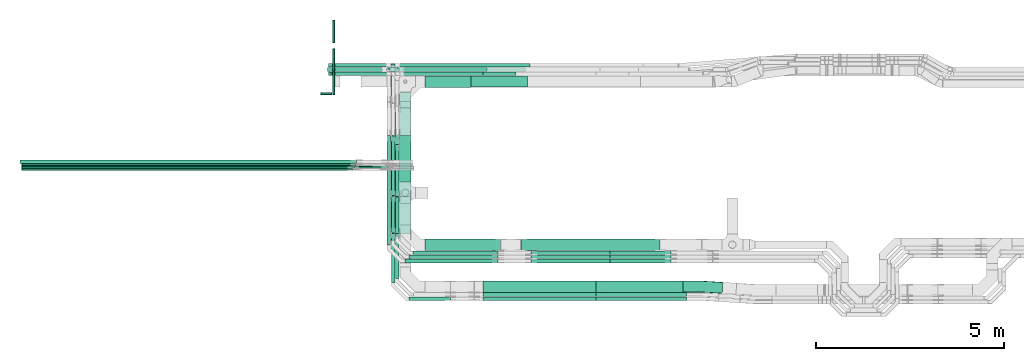
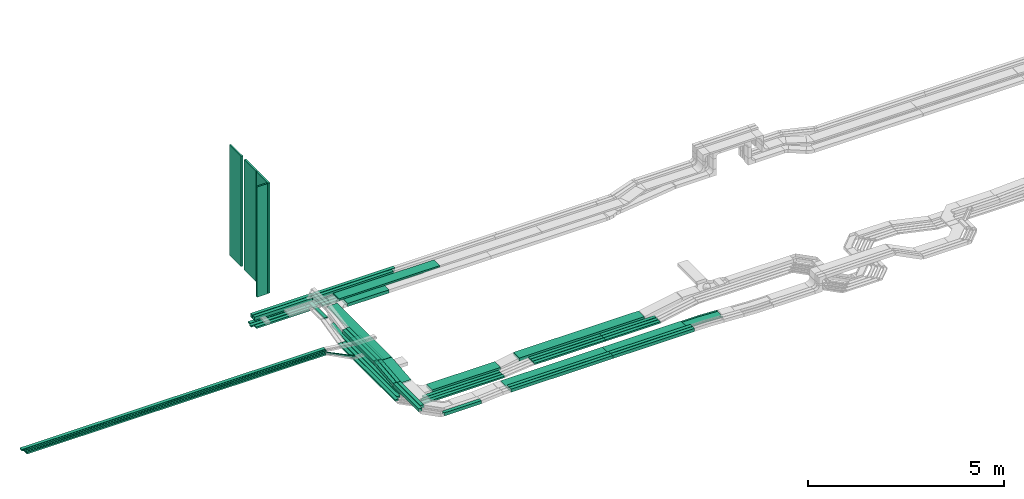
# One storey, part 1 of 33: 53 flow segments, 1 flow fitting.
"""IFC2X3 building model written with IfcOpenShell, lengths in millimetres."""

from ifc_helpers import new_model, entity, si_unit, converted_unit, derived_unit, direction, frame, frame_2d, origin, origin_2d_with_axis, place, context, subcontext, project, spatial, rectangle, extrude, faceted_brep, source, transform, mapped, material, type_object, type_shapes, element, save


model = new_model("IFC2X3")

# Units and contexts
model_context = context("Model", 3, precision=0.01, world=origin(), true_north=direction((6.12303176911189e-17, 1.0)))
body_context = subcontext(model_context, "Body", "Model", "MODEL_VIEW")
ifc_project = project(units=[si_unit("LENGTHUNIT", "METRE", prefix="MILLI"), si_unit("AREAUNIT", "SQUARE_METRE"), si_unit("VOLUMEUNIT", "CUBIC_METRE"), converted_unit("PLANEANGLEUNIT", "DEGREE", entity("IfcRatioMeasure", 0.0174532925199433), si_unit("PLANEANGLEUNIT", "RADIAN"), dimensions=[0, 0, 0, 0, 0, 0, 0]), si_unit("MASSUNIT", "GRAM", prefix="KILO"), derived_unit("MASSDENSITYUNIT", [(si_unit("MASSUNIT", "GRAM", prefix="KILO"), 1), (si_unit("LENGTHUNIT", "METRE"), -3)]), derived_unit("MOMENTOFINERTIAUNIT", [(si_unit("LENGTHUNIT", "METRE"), 4)]), si_unit("TIMEUNIT", "SECOND"), si_unit("FREQUENCYUNIT", "HERTZ"), si_unit("THERMODYNAMICTEMPERATUREUNIT", "DEGREE_CELSIUS"), derived_unit("THERMALTRANSMITTANCEUNIT", [(si_unit("MASSUNIT", "GRAM", prefix="KILO"), 1), (si_unit("THERMODYNAMICTEMPERATUREUNIT", "KELVIN"), -1), (si_unit("TIMEUNIT", "SECOND"), -3)]), derived_unit("VOLUMETRICFLOWRATEUNIT", [(si_unit("LENGTHUNIT", "METRE"), 3), (si_unit("TIMEUNIT", "SECOND"), -1)]), derived_unit("MASSFLOWRATEUNIT", [(si_unit("MASSUNIT", "GRAM", prefix="KILO"), 1), (si_unit("TIMEUNIT", "SECOND"), -1)]), derived_unit("ROTATIONALFREQUENCYUNIT", [(si_unit("TIMEUNIT", "SECOND"), -1)]), si_unit("ELECTRICCURRENTUNIT", "AMPERE"), si_unit("ELECTRICVOLTAGEUNIT", "VOLT"), si_unit("POWERUNIT", "WATT"), si_unit("FORCEUNIT", "NEWTON", prefix="KILO"), si_unit("ILLUMINANCEUNIT", "LUX"), si_unit("LUMINOUSFLUXUNIT", "LUMEN"), si_unit("LUMINOUSINTENSITYUNIT", "CANDELA"), derived_unit("USERDEFINED", [(si_unit("MASSUNIT", "GRAM", prefix="KILO"), -1), (si_unit("LENGTHUNIT", "METRE"), -2), (si_unit("TIMEUNIT", "SECOND"), 3), (si_unit("LUMINOUSFLUXUNIT", "LUMEN"), 1)]), derived_unit("LINEARVELOCITYUNIT", [(si_unit("LENGTHUNIT", "METRE"), 1), (si_unit("TIMEUNIT", "SECOND"), -1)]), si_unit("PRESSUREUNIT", "PASCAL"), derived_unit("USERDEFINED", [(si_unit("LENGTHUNIT", "METRE"), -2), (si_unit("MASSUNIT", "GRAM", prefix="KILO"), 1), (si_unit("TIMEUNIT", "SECOND"), -2)]), derived_unit("LINEARFORCEUNIT", [(si_unit("MASSUNIT", "GRAM", prefix="KILO"), 1), (si_unit("LENGTHUNIT", "METRE"), 1), (si_unit("TIMEUNIT", "SECOND"), -2), (si_unit("LENGTHUNIT", "METRE"), -1)]), derived_unit("PLANARFORCEUNIT", [(si_unit("MASSUNIT", "GRAM", prefix="KILO"), 1), (si_unit("LENGTHUNIT", "METRE"), 1), (si_unit("TIMEUNIT", "SECOND"), -2), (si_unit("LENGTHUNIT", "METRE"), -2)])], contexts=[model_context])

# Site, building, storey
site_placement = place(None, frame((0.0, -0.00077364408347762, 0.0)))
site = spatial("IfcSite", under=ifc_project, at=site_placement, CompositionType="ELEMENT")
building_placement = place(site_placement, origin())
building = spatial("IfcBuilding", under=site, at=building_placement, CompositionType="ELEMENT")
storey_placement = place(building_placement, frame((0.0, 0.0, 8100.0)))
storey = spatial("IfcBuildingStorey", under=building, at=storey_placement, CompositionType="ELEMENT", Elevation=8100.0)

# Flow segments
cable_carrier_segment_type_1 = type_object("IfcCableCarrierSegmentType", PredefinedType="CABLETRAYSEGMENT")
flow_segment_1_placement = place(storey_placement, frame((18361.0123642174, 14492.2782357463, 2565.34290576127)))
element("IfcFlowSegment", 1, at=flow_segment_1_placement, inside=storey, type_object=cable_carrier_segment_type_1, context=body_context, shape_type="SweptSolid", body=[
    extrude(rectangle(XDim=2981.2300000051, YDim=99.9999999999989, at=frame_2d((-1.02318153949454e-12, 1.08357767203415e-12), x_axis=(1.0, 0.0))), frame((1490.61500000255, 50.0, 0.0)), (0.0, 0.0, 1.0), 50.0000000000016),
])
flow_segment_2_placement = place(storey_placement, frame((16421.3046695845, 14492.2782357463, 2565.34290576127)))
element("IfcFlowSegment", 2, at=flow_segment_2_placement, inside=storey, type_object=cable_carrier_segment_type_1, context=body_context, shape_type="SweptSolid", body=[
    extrude(rectangle(XDim=1579.7076946329, YDim=99.9999999999989, at=frame_2d((1.08002495835535e-12, 2.16715534406831e-12), x_axis=(1.0, 0.0))), frame((789.853847316452, 50.0, 0.0), z_axis=(0.0, 0.0, 1.0), x_axis=(-1.0, 0.0, 0.0)), (0.0, 0.0, 1.0), 50.0000000000016),
])
flow_segment_3_placement = place(storey_placement, frame((16331.5056084794, 14602.2782357463, 2570.0)))
element("IfcFlowSegment", 3, at=flow_segment_3_placement, inside=storey, type_object=cable_carrier_segment_type_1, context=body_context, shape_type="SweptSolid", body=[
    extrude(rectangle(XDim=1629.50675573799, YDim=99.9999999999989, at=frame_2d((2.1600499167107e-12, 0.0), x_axis=(1.0, 0.0))), frame((814.753377868999, 50.0, 0.0), z_axis=(0.0, 0.0, 1.0), x_axis=(-1.0, 0.0, 0.0)), (0.0, 0.0, 1.0), 50.0000000000016),
])
flow_segment_4_placement = place(storey_placement, frame((18676.0523642072, 14182.2782357464, 2840.01712441882)))
element("IfcFlowSegment", 4, at=flow_segment_4_placement, inside=storey, type_object=cable_carrier_segment_type_1, context=body_context, shape_type="SweptSolid", body=[
    extrude(rectangle(XDim=2971.23000000509, YDim=300.000000000001, at=frame_2d((-1.13686837721616e-12, 2.17426077142591e-12), x_axis=(1.0, 0.0))), frame((1485.61500000254, 150.0, 0.0)), (0.0, 0.0, 1.0), 50.0000000000016),
])
flow_segment_5_placement = place(storey_placement, frame((18076.0523642072, 14492.2782357464, 2840.0)))
element("IfcFlowSegment", 5, at=flow_segment_5_placement, inside=storey, type_object=cable_carrier_segment_type_1, context=body_context, shape_type="SweptSolid", body=[
    extrude(rectangle(XDim=2385.50742869904, YDim=99.9999999999989, at=frame_2d((1.02318153949454e-12, 1.08357767203415e-12), x_axis=(1.0, 0.0))), frame((1192.75371434952, 50.0, 0.0), z_axis=(0.0, 0.0, 1.0), x_axis=(-1.0, 0.0, 0.0)), (0.0, 0.0, 1.0), 99.9999999999989),
])
flow_segment_6_placement = place(storey_placement, frame((18186.0523642072, 14602.2782357463, 2840.0)))
element("IfcFlowSegment", 6, at=flow_segment_6_placement, inside=storey, type_object=cable_carrier_segment_type_1, context=body_context, shape_type="SweptSolid", body=[
    extrude(rectangle(XDim=2385.50742869902, YDim=99.9999999999989, at=origin_2d_with_axis()), frame((1192.75371434951, 50.0, 0.0), z_axis=(0.0, 0.0, 1.0), x_axis=(-1.0, 0.0, 0.0)), (0.0, 0.0, 1.0), 99.9999999999989),
])
flow_segment_7_placement = place(storey_placement, frame((18922.0523642072, 9844.99855346682, 2500.0)))
element("IfcFlowSegment", 7, at=flow_segment_7_placement, inside=storey, type_object=cable_carrier_segment_type_1, context=body_context, shape_type="SweptSolid", body=[
    extrude(rectangle(XDim=2011.88022352649, YDim=300.000000000001, at=frame_2d((0.0, 1.08002495835535e-12), x_axis=(1.0, 0.0))), frame((1005.94011176324, 150.0, 0.0)), (0.0, 0.0, 1.0), 99.9999999999989),
])
flow_segment_8_placement = place(storey_placement, frame((23464.785458641, 8622.45182054443, 2789.66918252178)))
element("IfcFlowSegment", 8, at=flow_segment_8_placement, inside=storey, type_object=cable_carrier_segment_type_1, context=body_context, shape_type="SweptSolid", body=[
    extrude(rectangle(XDim=2411.83602414101, YDim=100.000000000001, at=frame_2d((2.1600499167107e-12, -5.43565192856477e-13), x_axis=(1.0, 0.0))), frame((1205.9180120705, 50.0, 0.0)), (0.0, 0.0, 1.0), 99.9999999999989),
])
flow_segment_9_placement = place(storey_placement, frame((23462.6214827823, 8732.04668110773, 2790.01530223368)))
element("IfcFlowSegment", 9, at=flow_segment_9_placement, inside=storey, type_object=cable_carrier_segment_type_1, context=body_context, shape_type="SweptSolid", body=[
    extrude(rectangle(XDim=2314.00000000008, YDim=299.999999999999, at=frame_2d((0.0, -5.40012479177676e-13), x_axis=(1.0, 0.0))), frame((1157.0, 150.0, 0.0)), (0.0, 0.0, 1.0), 50.0000000000016),
])
flow_segment_10_placement = place(storey_placement, frame((23468.9375315248, 8512.45182054444, 2789.31932519732)))
element("IfcFlowSegment", 10, at=flow_segment_10_placement, inside=storey, type_object=cable_carrier_segment_type_1, context=body_context, shape_type="SweptSolid", body=[
    extrude(rectangle(XDim=2407.68395125738, YDim=99.9999999999989, at=frame_2d((2.27373675443232e-12, 5.40012479177676e-13), x_axis=(1.0, 0.0))), frame((1203.84197562869, 50.0, 0.0)), (0.0, 0.0, 1.0), 99.9999999999989),
])
flow_segment_11_placement = place(storey_placement, frame((18246.0523642072, 11278.2338711345, 2840.01533161616)))
element("IfcFlowSegment", 11, at=flow_segment_11_placement, inside=storey, type_object=cable_carrier_segment_type_1, context=body_context, shape_type="SweptSolid", body=[
    extrude(rectangle(XDim=2774.04434845544, YDim=299.999999999997, at=frame_2d((0.0, -1.08002495835535e-12), x_axis=(1.0, 0.0))), frame((150.0, 1387.02220654132, 0.000896401333943686), z_axis=(0.0, -6.46277580620266e-07, 1.0), x_axis=(0.0, -1.0, -6.46277580620266e-07)), (0.0, 0.0, 1.0), 49.9999999999991),
])
flow_segment_12_placement = place(storey_placement, frame((18246.0523642072, 11656.2465616803, 2500.0)))
element("IfcFlowSegment", 12, at=flow_segment_12_placement, inside=storey, type_object=cable_carrier_segment_type_1, context=body_context, shape_type="SweptSolid", body=[
    extrude(rectangle(XDim=1245.36492297945, YDim=300.000000000001, at=frame_2d((0.0, -1.08002495835535e-12), x_axis=(1.0, 0.0))), frame((150.0, 622.682461489727, 0.0), z_axis=(0.0, 0.0, 1.0), x_axis=(0.0, -1.0, 0.0)), (0.0, 0.0, 1.0), 99.9999999999989),
])
flow_segment_13_placement = place(storey_placement, frame((16359.5829619709, 14712.2782357463, 2570.0)))
element("IfcFlowSegment", 13, at=flow_segment_13_placement, inside=storey, type_object=cable_carrier_segment_type_1, context=body_context, shape_type="SweptSolid", body=[
    extrude(rectangle(XDim=1711.42940224653, YDim=99.9999999999989, at=frame_2d((-1.08002495835535e-12, 0.0), x_axis=(1.0, 0.0))), frame((855.714701123265, 50.0, 0.0), z_axis=(0.0, 0.0, 1.0), x_axis=(-1.0, 0.0, 0.0)), (0.0, 0.0, 1.0), 49.9999999999995),
])
flow_segment_14_placement = place(storey_placement, frame((23838.8758454154, 9734.99855346671, 2589.15529134035)))
element("IfcFlowSegment", 14, at=flow_segment_14_placement, inside=storey, type_object=cable_carrier_segment_type_1, context=body_context, shape_type="SweptSolid", body=[
    extrude(rectangle(XDim=1615.92542255297, YDim=99.9999999999989, at=frame_2d((2.1600499167107e-12, 0.0), x_axis=(1.0, 0.0))), frame((807.96271127649, 50.0, 0.0)), (0.0, 0.0, 1.0), 50.0000000000016),
])
flow_segment_15_placement = place(storey_placement, frame((23838.8758454154, 9625.47519661139, 2590.43110636496)))
element("IfcFlowSegment", 15, at=flow_segment_15_placement, inside=storey, type_object=cable_carrier_segment_type_1, context=body_context, shape_type="SweptSolid", body=[
    extrude(rectangle(XDim=1615.94124469224, YDim=99.9999999999989, at=frame_2d((0.0, 5.40012479177676e-13), x_axis=(1.0, 0.0))), frame((807.970622346122, 50.0, 0.0)), (0.0, 0.0, 1.0), 50.0000000000016),
])
flow_segment_16_placement = place(storey_placement, frame((23838.8758454154, 9515.47519661139, 2590.49251454768)))
element("IfcFlowSegment", 16, at=flow_segment_16_placement, inside=storey, type_object=cable_carrier_segment_type_1, context=body_context, shape_type="SweptSolid", body=[
    extrude(rectangle(XDim=1615.94353988623, YDim=100.000000000001, at=frame_2d((2.1600499167107e-12, 5.43565192856477e-13), x_axis=(1.0, 0.0))), frame((807.971769943115, 50.0, 0.0)), (0.0, 0.0, 1.0), 50.0000000000016),
])
flow_segment_17_placement = place(storey_placement, frame((21484.2502536627, 9844.99855346682, 2595.01712441879)))
element("IfcFlowSegment", 17, at=flow_segment_17_placement, inside=storey, type_object=cable_carrier_segment_type_1, context=body_context, shape_type="SweptSolid", body=[
    extrude(rectangle(XDim=3688.2870636457, YDim=300.000000000001, at=frame_2d((0.0, -1.08002495835535e-12), x_axis=(1.0, 0.0))), frame((1844.14353182285, 150.0, 0.0)), (0.0, 0.0, 1.0), 99.9999999999989),
])
flow_segment_18_placement = place(storey_placement, frame((18502.0523642074, 8512.45182054443, 2739.32351929119)))
element("IfcFlowSegment", 18, at=flow_segment_18_placement, inside=storey, type_object=cable_carrier_segment_type_1, context=body_context, shape_type="SweptSolid", body=[
    extrude(rectangle(XDim=1090.93059039301, YDim=100.000000000001, at=frame_2d((2.1600499167107e-12, 0.0), x_axis=(1.0, 0.0))), frame((545.465295196512, 50.0, 0.0), z_axis=(0.0, 0.0, 1.0), x_axis=(-1.0, 0.0, 0.0)), (0.0, 0.0, 1.0), 100.000000000001),
])
flow_segment_19_placement = place(storey_placement, frame((8199.58296197092, 12091.7526237039, 3060.0)))
element("IfcFlowSegment", 19, at=flow_segment_19_placement, inside=storey, type_object=cable_carrier_segment_type_1, context=body_context, shape_type="SweptSolid", body=[
    extrude(rectangle(XDim=8897.16239513093, YDim=50.0000000000016, at=frame_2d((0.0, -1.08357767203415e-12), x_axis=(1.0, 0.0))), frame((4448.58119756547, 25.0, 0.0), z_axis=(0.0, 0.0, 1.0), x_axis=(-1.0, 0.0, 0.0)), (0.0, 0.0, 1.0), 50.0000000000016),
])
flow_segment_20_placement = place(storey_placement, frame((18922.0523642072, 14174.4992263561, 2565.0)))
element("IfcFlowSegment", 20, at=flow_segment_20_placement, inside=storey, type_object=cable_carrier_segment_type_1, context=body_context, shape_type="SweptSolid", body=[
    extrude(rectangle(XDim=1223.84496020994, YDim=300.000000000001, at=frame_2d((2.1600499167107e-12, 1.08002495835535e-12), x_axis=(1.0, 0.0))), frame((611.922480104978, 150.0, 0.0), z_axis=(0.0, 0.0, 1.0), x_axis=(-1.0, 0.0, 0.0)), (0.0, 0.0, 1.0), 99.9999999999989),
])
flow_segment_21_placement = place(storey_placement, frame((20462.6214827823, 8732.04668110773, 2790.01530223369)))
element("IfcFlowSegment", 21, at=flow_segment_21_placement, inside=storey, type_object=cable_carrier_segment_type_1, context=body_context, shape_type="SweptSolid", body=[
    extrude(rectangle(XDim=2997.46000001016, YDim=299.999999999999, at=origin_2d_with_axis()), frame((1498.73000000508, 150.0, 0.0), z_axis=(0.0, 0.0, 1.0), x_axis=(-1.0, 0.0, 0.0)), (0.0, 0.0, 1.0), 50.0000000000016),
])
flow_segment_22_placement = place(storey_placement, frame((8199.58296197093, 12031.7526237039, 3060.0)))
element("IfcFlowSegment", 22, at=flow_segment_22_placement, inside=storey, type_object=cable_carrier_segment_type_1, context=body_context, shape_type="SweptSolid", body=[
    extrude(rectangle(XDim=8812.29056112652, YDim=50.0000000000016, at=frame_2d((1.36424205265939e-12, 1.08357767203415e-12), x_axis=(1.0, 0.0))), frame((4406.14528056326, 25.0, 0.0), z_axis=(0.0, 0.0, 1.0), x_axis=(-1.0, 0.0, 0.0)), (0.0, 0.0, 1.0), 50.0000000000016),
])
flow_segment_23_placement = place(storey_placement, frame((8199.58296197093, 11971.7526237039, 3060.0)))
element("IfcFlowSegment", 23, at=flow_segment_23_placement, inside=storey, type_object=cable_carrier_segment_type_1, context=body_context, shape_type="SweptSolid", body=[
    extrude(rectangle(XDim=8811.8645785195, YDim=50.0000000000016, at=frame_2d((-9.09494701772928e-13, 0.0), x_axis=(1.0, 0.0))), frame((4405.93228925975, 25.0, 0.0), z_axis=(0.0, 0.0, 1.0), x_axis=(-1.0, 0.0, 0.0)), (0.0, 0.0, 1.0), 50.0000000000016),
])
flow_segment_24_placement = place(storey_placement, frame((20464.785458641, 8622.45182054443, 2789.66918252179)))
element("IfcFlowSegment", 24, at=flow_segment_24_placement, inside=storey, type_object=cable_carrier_segment_type_1, context=body_context, shape_type="SweptSolid", body=[
    extrude(rectangle(XDim=2997.46000001016, YDim=100.000000000001, at=frame_2d((0.0, 5.43565192856477e-13), x_axis=(1.0, 0.0))), frame((1498.73000000508, 50.0, 0.0), z_axis=(0.0, 0.0, 1.0), x_axis=(-1.0, 0.0, 0.0)), (0.0, 0.0, 1.0), 99.9999999999989),
])
flow_segment_25_placement = place(storey_placement, frame((20468.9375315248, 8512.45182054444, 2789.31932519733)))
element("IfcFlowSegment", 25, at=flow_segment_25_placement, inside=storey, type_object=cable_carrier_segment_type_1, context=body_context, shape_type="SweptSolid", body=[
    extrude(rectangle(XDim=2997.46000001016, YDim=99.9999999999989, at=origin_2d_with_axis()), frame((1498.73000000508, 50.0, 0.0), z_axis=(0.0, 0.0, 1.0), x_axis=(-1.0, 0.0, 0.0)), (0.0, 0.0, 1.0), 99.9999999999989),
])
flow_segment_26_placement = place(storey_placement, frame((8159.58296197093, 12151.7526237039, 3060.0)))
element("IfcFlowSegment", 26, at=flow_segment_26_placement, inside=storey, type_object=cable_carrier_segment_type_1, context=body_context, shape_type="SweptSolid", body=[
    extrude(rectangle(XDim=8936.98769079436, YDim=99.9999999999989, at=frame_2d((-4.54747350886464e-13, -1.08357767203415e-12), x_axis=(1.0, 0.0))), frame((4468.49384539718, 50.0, 0.0), z_axis=(0.0, 0.0, 1.0), x_axis=(-1.0, 0.0, 0.0)), (0.0, 0.0, 1.0), 50.0000000000016),
])
flow_segment_27_placement = place(storey_placement, frame((18607.0123642174, 9734.99855346671, 2495.32100561213)))
element("IfcFlowSegment", 27, at=flow_segment_27_placement, inside=storey, type_object=cable_carrier_segment_type_1, context=body_context, shape_type="SweptSolid", body=[
    extrude(rectangle(XDim=2253.98527272605, YDim=99.9999999999989, at=frame_2d((1.02318153949454e-12, 0.0), x_axis=(1.0, 0.0))), frame((1126.99263636302, 50.0, 0.0), z_axis=(0.0, 0.0, 1.0), x_axis=(-1.0, 0.0, 0.0)), (0.0, 0.0, 1.0), 50.0000000000016),
])
flow_segment_28_placement = place(storey_placement, frame((18497.0123642174, 9625.47519661138, 2495.46732994374)))
element("IfcFlowSegment", 28, at=flow_segment_28_placement, inside=storey, type_object=cable_carrier_segment_type_1, context=body_context, shape_type="SweptSolid", body=[
    extrude(rectangle(XDim=2363.95663058173, YDim=99.9999999999989, at=frame_2d((1.02318153949454e-12, 0.0), x_axis=(1.0, 0.0))), frame((1181.97831529086, 50.0, 0.0), z_axis=(0.0, 0.0, 1.0), x_axis=(-1.0, 0.0, 0.0)), (0.0, 0.0, 1.0), 50.0000000000016),
])
flow_segment_29_placement = place(storey_placement, frame((18387.0123642174, 9515.4751966114, 2500.0)))
element("IfcFlowSegment", 29, at=flow_segment_29_placement, inside=storey, type_object=cable_carrier_segment_type_1, context=body_context, shape_type="SweptSolid", body=[
    extrude(rectangle(XDim=2473.54052636319, YDim=100.000000000001, at=frame_2d((-1.13686837721616e-12, 0.0), x_axis=(1.0, 0.0))), frame((1236.77026318159, 50.0, 0.0), z_axis=(0.0, 0.0, 1.0), x_axis=(-1.0, 0.0, 0.0)), (0.0, 0.0, 1.0), 50.0000000000016),
])
flow_segment_30_placement = place(storey_placement, frame((18131.0123642174, 12665.2766961666, 2495.51594236306)))
element("IfcFlowSegment", 30, at=flow_segment_30_placement, inside=storey, type_object=cable_carrier_segment_type_1, context=body_context, shape_type="SweptSolid", body=[
    extrude(rectangle(XDim=49.9999999999999, YDim=1019.51076030492, at=frame_2d((-2.1600499167107e-12, 1.49213974509621e-13), x_axis=(0.0, 1.0))), frame((0.0, 510.27137863454, 59.8160133236435), z_axis=(1.0, 0.0, 0.0), x_axis=(0.0, 0.997656992775831, 0.0684143608132536)), (0.0, 0.0, 1.0), 99.9999999999989),
])
flow_segment_31_placement = place(storey_placement, frame((18021.0123642174, 13788.8229972441, 2710.72359538162)))
element("IfcFlowSegment", 31, at=flow_segment_31_placement, inside=storey, type_object=cable_carrier_segment_type_1, context=body_context, shape_type="SweptSolid", body=[
    extrude(rectangle(XDim=1004.45523850221, YDim=99.9999999999989, at=frame_2d((0.0, -1.08357767203415e-12), x_axis=(1.0, 0.0))), frame((50.0, 502.227619251104, 0.0), z_axis=(0.0, 0.0, 1.0), x_axis=(0.0, 1.0, 0.0)), (0.0, 0.0, 1.0), 50.0000000000038),
])
flow_segment_32_placement = place(storey_placement, frame((18072.0123642175, 14712.2782357463, 2570.0)))
element("IfcFlowSegment", 32, at=flow_segment_32_placement, inside=storey, type_object=cable_carrier_segment_type_1, context=body_context, shape_type="SweptSolid", body=[
    extrude(rectangle(XDim=3635.06094064414, YDim=99.9999999999989, at=frame_2d((-1.13686837721616e-12, 1.08357767203415e-12), x_axis=(1.0, 0.0))), frame((1817.53047032207, 50.0, 0.0), z_axis=(0.0, 0.0, 1.0), x_axis=(-1.0, 0.0, 0.0)), (0.0, 0.0, 1.0), 50.0000000000016),
])
flow_segment_33_placement = place(storey_placement, frame((17962.0123642174, 14602.2782357463, 2570.0)))
element("IfcFlowSegment", 33, at=flow_segment_33_placement, inside=storey, type_object=cable_carrier_segment_type_1, context=body_context, shape_type="SweptSolid", body=[
    extrude(rectangle(XDim=3629.49324426201, YDim=99.9999999999989, at=frame_2d((-2.1600499167107e-12, 1.08357767203415e-12), x_axis=(1.0, 0.0))), frame((1814.74662213101, 50.0, 0.0), z_axis=(0.0, 0.0, 1.0), x_axis=(-1.0, 0.0, 0.0)), (0.0, 0.0, 1.0), 50.0000000000016),
])
flow_segment_34_placement = place(storey_placement, frame((18136.0523642072, 11279.5295854872, 2840.0)))
element("IfcFlowSegment", 34, at=flow_segment_34_placement, inside=storey, type_object=cable_carrier_segment_type_1, context=body_context, shape_type="SweptSolid", body=[
    extrude(rectangle(XDim=1630.30438948267, YDim=99.9999999999989, at=frame_2d((1.08002495835535e-12, 0.0), x_axis=(1.0, 0.0))), frame((50.0, 815.152194741335, 0.0), z_axis=(0.0, 0.0, 1.0), x_axis=(0.0, 1.0, 0.0)), (0.0, 0.0, 1.0), 99.9999999999989),
])
flow_segment_35_placement = place(storey_placement, frame((18026.0523642073, 11299.5077713601, 2840.0)))
element("IfcFlowSegment", 35, at=flow_segment_35_placement, inside=storey, type_object=cable_carrier_segment_type_1, context=body_context, shape_type="SweptSolid", body=[
    extrude(rectangle(XDim=1589.99978553911, YDim=99.9999999999989, at=frame_2d((1.13686837721616e-12, 1.08357767203415e-12), x_axis=(1.0, 0.0))), frame((50.0, 794.999892769556, 0.0), z_axis=(0.0, 0.0, 1.0), x_axis=(0.0, 1.0, 0.0)), (0.0, 0.0, 1.0), 99.9999999999989),
])
flow_segment_36_placement = place(storey_placement, frame((18136.0523642073, 9098.45182054445, 2739.53642365383)))
element("IfcFlowSegment", 36, at=flow_segment_36_placement, inside=storey, type_object=cable_carrier_segment_type_1, context=body_context, shape_type="SweptSolid", body=[
    extrude(rectangle(XDim=1190.24865025856, YDim=99.9999999999989, at=origin_2d_with_axis()), frame((50.0, 595.124325129284, 0.0), z_axis=(0.0, 0.0, 1.0), x_axis=(0.0, -1.0, 0.0)), (0.0, 0.0, 1.0), 99.9999999999968),
])
flow_segment_37_placement = place(storey_placement, frame((18026.0523642074, 8988.45182054451, 2739.32351929119)))
element("IfcFlowSegment", 37, at=flow_segment_37_placement, inside=storey, type_object=cable_carrier_segment_type_1, context=body_context, shape_type="SweptSolid", body=[
    extrude(rectangle(XDim=1310.27046438656, YDim=99.9999999999989, at=frame_2d((-5.11590769747272e-13, 1.08357767203415e-12), x_axis=(1.0, 0.0))), frame((50.0, 655.135232193284, 0.0), z_axis=(0.0, 0.0, 1.0), x_axis=(0.0, -1.0, 0.0)), (0.0, 0.0, 1.0), 99.9999999999989),
])
flow_segment_38_placement = place(storey_placement, frame((18026.0523642075, 10301.1205330662, 2739.95444010973)))
element("IfcFlowSegment", 38, at=flow_segment_38_placement, inside=storey, type_object=cable_carrier_segment_type_1, context=body_context, shape_type="SweptSolid", body=[
    extrude(rectangle(XDim=100.000000000002, YDim=99.9999999999989, at=frame_2d((-1.06581410364015e-13, 0.0), x_axis=(1.0, 0.0))), frame((50.0, 5.04181377342869, 49.7451516619875), z_axis=(0.0, 0.994903033239733, 0.100836275468594), x_axis=(0.0, -0.100836275468594, 0.994903033239733)), (0.0, 0.0, 1.0), 990.956233595495),
])
flow_segment_39_placement = place(storey_placement, frame((18136.0523642073, 10291.1018442155, 2740.17663076466)))
element("IfcFlowSegment", 39, at=flow_segment_39_placement, inside=storey, type_object=cable_carrier_segment_type_1, context=body_context, shape_type="SweptSolid", body=[
    extrude(rectangle(XDim=99.9999999999988, YDim=980.942427474035, at=frame_2d((1.08002495835535e-12, -1.10134124042816e-13), x_axis=(0.0, 1.0))), frame((0.0, 493.013183929629, 99.59158106245), z_axis=(1.0, 0.0, 0.0), x_axis=(0.0, 0.994821450765378, 0.101637990422228)), (0.0, 0.0, 1.0), 100.000000000001),
])
flow_segment_40_placement = place(storey_placement, frame((18246.0523642074, 10281.9866852872, 2740.38679642176)))
element("IfcFlowSegment", 40, at=flow_segment_40_placement, inside=storey, type_object=cable_carrier_segment_type_1, context=body_context, shape_type="SweptSolid", body=[
    extrude(rectangle(XDim=50.0000000000003, YDim=993.839659670533, at=frame_2d((-1.08002495835535e-12, 1.10134124042816e-13), x_axis=(0.0, 1.0))), frame((0.0, 496.925863346215, 74.6285261170298), z_axis=(1.0, 0.0, 0.0), x_axis=(0.0, 0.994974854702739, 0.100125114278404)), (0.0, 0.0, 1.0), 300.000000000001),
])
flow_segment_41_placement = place(storey_placement, frame((16359.5829619709, 14492.2782357463, 2840.0)))
element("IfcFlowSegment", 41, at=flow_segment_41_placement, inside=storey, type_object=cable_carrier_segment_type_1, context=body_context, shape_type="SweptSolid", body=[
    extrude(rectangle(XDim=1715.46940223623, YDim=99.9999999999989, at=frame_2d((-1.08002495835535e-12, 0.0), x_axis=(1.0, 0.0))), frame((857.734701118114, 50.0, 0.0), z_axis=(0.0, 0.0, 1.0), x_axis=(-1.0, 0.0, 0.0)), (0.0, 0.0, 1.0), 99.9999999999989),
])
flow_segment_42_placement = place(storey_placement, frame((16359.5829619709, 14602.2782357463, 2840.0)))
element("IfcFlowSegment", 42, at=flow_segment_42_placement, inside=storey, type_object=cable_carrier_segment_type_1, context=body_context, shape_type="SweptSolid", body=[
    extrude(rectangle(XDim=1825.46940223625, YDim=99.9999999999989, at=frame_2d((2.1600499167107e-12, -1.08357767203415e-12), x_axis=(1.0, 0.0))), frame((912.734701118129, 50.0, 0.0), z_axis=(0.0, 0.0, 1.0), x_axis=(-1.0, 0.0, 0.0)), (0.0, 0.0, 1.0), 99.9999999999989),
])
flow_segment_43_placement = place(storey_placement, frame((18021.0123642174, 10101.4751966114, 2495.46732994374)))
element("IfcFlowSegment", 43, at=flow_segment_43_placement, inside=storey, type_object=cable_carrier_segment_type_1, context=body_context, shape_type="SweptSolid", body=[
    extrude(rectangle(XDim=2799.02544525247, YDim=99.9999999999989, at=frame_2d((1.13686837721616e-12, 1.08357767203415e-12), x_axis=(1.0, 0.0))), frame((50.0, 1399.51272262624, 0.0), z_axis=(0.0, 0.0, 1.0), x_axis=(0.0, 1.0, 0.0)), (0.0, 0.0, 1.0), 50.0000000000016),
])
flow_segment_44_placement = place(storey_placement, frame((17911.0123642174, 9991.4751966114, 2500.0)))
element("IfcFlowSegment", 44, at=flow_segment_44_placement, inside=storey, type_object=cable_carrier_segment_type_1, context=body_context, shape_type="SweptSolid", body=[
    extrude(rectangle(XDim=2909.02544525244, YDim=99.9999999999989, at=frame_2d((0.0, -1.08357767203415e-12), x_axis=(1.0, 0.0))), frame((50.0, 1454.51272262622, 0.0), z_axis=(0.0, 0.0, 1.0), x_axis=(0.0, 1.0, 0.0)), (0.0, 0.0, 1.0), 50.0000000000016),
])
flow_segment_45_placement = place(storey_placement, frame((18131.0123642174, 10210.9985534667, 2495.32100561214)))
element("IfcFlowSegment", 45, at=flow_segment_45_placement, inside=storey, type_object=cable_carrier_segment_type_1, context=body_context, shape_type="SweptSolid", body=[
    extrude(rectangle(XDim=2452.00682826396, YDim=99.9999999999989, at=frame_2d((1.13686837721616e-12, 0.0), x_axis=(1.0, 0.0))), frame((50.0, 1226.00341413198, 0.0), z_axis=(0.0, 0.0, 1.0), x_axis=(0.0, 1.0, 0.0)), (0.0, 0.0, 1.0), 50.0000000000016),
])
flow_segment_46_placement = place(storey_placement, frame((21742.1664952768, 9515.47519661139, 2590.4925145477)))
element("IfcFlowSegment", 46, at=flow_segment_46_placement, inside=storey, type_object=cable_carrier_segment_type_1, context=body_context, shape_type="SweptSolid", body=[
    extrude(rectangle(XDim=2094.1693501488, YDim=100.000000000001, at=origin_2d_with_axis()), frame((1047.0846750744, 50.0, 0.0)), (0.0, 0.0, 1.0), 50.0000000000016),
])
flow_segment_47_placement = place(storey_placement, frame((21741.444320915, 9625.47519661138, 2590.43110636496)))
element("IfcFlowSegment", 47, at=flow_segment_47_placement, inside=storey, type_object=cable_carrier_segment_type_1, context=body_context, shape_type="SweptSolid", body=[
    extrude(rectangle(XDim=2094.8915245106, YDim=99.9999999999989, at=frame_2d((-2.1600499167107e-12, -1.08357767203415e-12), x_axis=(1.0, 0.0))), frame((1047.4457622553, 50.0, 0.0)), (0.0, 0.0, 1.0), 50.0000000000016),
])
flow_segment_48_placement = place(storey_placement, frame((21741.6514192943, 9734.99855346671, 2589.15529134037)))
element("IfcFlowSegment", 48, at=flow_segment_48_placement, inside=storey, type_object=cable_carrier_segment_type_1, context=body_context, shape_type="SweptSolid", body=[
    extrude(rectangle(XDim=2094.68442613129, YDim=99.9999999999989, at=frame_2d((0.0, -1.08357767203415e-12), x_axis=(1.0, 0.0))), frame((1047.34221306565, 50.0, 0.0)), (0.0, 0.0, 1.0), 50.0000000000016),
])
flow_segment_49_placement = place(storey_placement, frame((17015.5287479864, 12031.7526237039, 2625.92645464237)))
element("IfcFlowSegment", 49, at=flow_segment_49_placement, inside=storey, type_object=cable_carrier_segment_type_1, context=body_context, shape_type="SweptSolid", body=[
    extrude(rectangle(XDim=50.000000000001, YDim=50.0000000000016, at=origin_2d_with_axis()), frame((10.9802533001277, 25.0, 455.687481692298), z_axis=(0.898384360919167, 0.0, -0.439210132005013), x_axis=(0.439210132005013, 0.0, 0.898384360919167)), (0.0, 0.0, 1.0), 986.379505162213),
])

# Flow fitting
ifc_material = material()
cable_carrier_fitting_type = type_object("IfcCableCarrierFittingType", Name="470_DKC_G5_Sheet horizontal bend:-", PredefinedType="NOTDEFINED", material=ifc_material)
shared_shape = source(origin(), body_context, "Body", "Brep", [
    faceted_brep([(-526.0, -150.0, -25.0), (-526.0, -150.0, 25.0), (-526.0, -145.0, 25.0), (-526.0, -145.0, -20.0), (-526.0, 145.0, -20.0), (-526.0, 145.0, 25.0), (-526.0, 150.0, 25.0), (-526.0, 150.0, -25.0), (4.75933073623803, -150.0, -25.0), (4.75933073623803, -150.0, 25.0), (534.451082788922, -116.353083782761, 25.0), (534.134113173234, -111.363140870991, 25.0), (4.60068637836366, -145.0, 25.0), (4.60068637836366, -145.0, -20.0), (534.134113173234, -111.363140870991, -20.0), (515.749875463334, 178.05354801171, -20.0), (-4.60068637835114, 145.0, -20.0), (-4.60068637835114, 145.0, 25.0), (515.749875463334, 178.05354801171, 25.0), (515.432905847646, 183.04349092348, 25.0), (-4.75933073622551, 150.0, 25.0), (-4.75933073622558, 150.0, -25.0), (515.432905847646, 183.043490923481, -25.0), (534.451082788922, -116.353083782761, -25.0)], [[[0, 1, 2, 3, 4, 5, 6, 7]], [[1, 0, 8, 9]], [[2, 1, 9, 10, 11, 12]], [[3, 2, 12, 13]], [[4, 3, 13, 14, 15, 16]], [[5, 4, 16, 17]], [[6, 5, 17, 18, 19, 20]], [[7, 6, 20, 21]], [[8, 0, 7, 21, 22, 23]], [[23, 22, 19, 18, 15, 14, 11, 10]], [[9, 8, 23, 10]], [[13, 12, 11, 14]], [[17, 16, 15, 18]], [[21, 20, 19, 22]]]),
])
type_shapes(cable_carrier_fitting_type, [shared_shape])
flow_fitting_placement = place(storey_placement, frame((26302.6214827825, 8882.04668110774, 2815.01530223368), z_axis=(0.0, 0.0, 1.0), x_axis=(-0.997988582354139, 0.0633939231375997, 0.0)))
element("IfcFlowFitting", 50, at=flow_fitting_placement, inside=storey, type_object=cable_carrier_fitting_type, material=ifc_material, Name="470_DKC_G5_Sheet horizontal bend:-", ObjectType="470_DKC_G5_Sheet horizontal bend:-", context=body_context, shape_type="MappedRepresentation", body=[
    mapped(shared_shape, transform((0.0, 0.0, 0.0), scale=1.0)),
])

# Flow segments
cable_carrier_segment_type_2 = type_object("IfcCableCarrierSegmentType", PredefinedType="CABLETRAYSEGMENT")
flow_segment_50_placement = place(storey_placement, frame((16472.305766128, 15367.6093717678, 3945.84199571755)))
element("IfcFlowSegment", 51, at=flow_segment_50_placement, inside=storey, type_object=cable_carrier_segment_type_2, context=body_context, shape_type="SweptSolid", body=[
    extrude(rectangle(XDim=50.0000000000016, YDim=600.000000000002, at=origin_2d_with_axis()), frame((25.0, 300.0, 0.0), z_axis=(0.0, 0.0, 1.0), x_axis=(-1.0, 0.0, 0.0)), (0.0, 0.0, 1.0), 3440.0),
])
flow_segment_51_placement = place(storey_placement, frame((16472.305766128, 14607.6093717678, 3945.84199571755)))
element("IfcFlowSegment", 52, at=flow_segment_51_placement, inside=storey, type_object=cable_carrier_segment_type_2, context=body_context, shape_type="SweptSolid", body=[
    extrude(rectangle(XDim=50.0000000000016, YDim=599.999999999998, at=frame_2d((0.0, -2.1600499167107e-12), x_axis=(1.0, 0.0))), frame((25.0, 300.0, 0.0), z_axis=(0.0, 0.0, 1.0), x_axis=(-1.0, 0.0, 0.0)), (0.0, 0.0, 1.0), 3440.0),
])
flow_segment_52_placement = place(storey_placement, frame((16472.305766128, 13987.6093717678, 3945.84199571755)))
element("IfcFlowSegment", 53, at=flow_segment_52_placement, inside=storey, type_object=cable_carrier_segment_type_2, context=body_context, shape_type="SweptSolid", body=[
    extrude(rectangle(XDim=50.0000000000016, YDim=600.000000000002, at=origin_2d_with_axis()), frame((25.0, 300.0, 0.0), z_axis=(0.0, 0.0, 1.0), x_axis=(-1.0, 0.0, 0.0)), (0.0, 0.0, 1.0), 3440.0),
])
flow_segment_53_placement = place(storey_placement, frame((16147.305766128, 13982.6093717678, 3945.84199571756)))
element("IfcFlowSegment", 54, at=flow_segment_53_placement, inside=storey, type_object=cable_carrier_segment_type_2, context=body_context, shape_type="SweptSolid", body=[
    extrude(rectangle(XDim=50.0000000000016, YDim=300.000000000001, at=origin_2d_with_axis()), frame((150.0, 25.0, 0.0), z_axis=(0.0, 0.0, 1.0), x_axis=(0.0, 1.0, 0.0)), (0.0, 0.0, 1.0), 3435.0),
])

save(model, "model.ifc")
